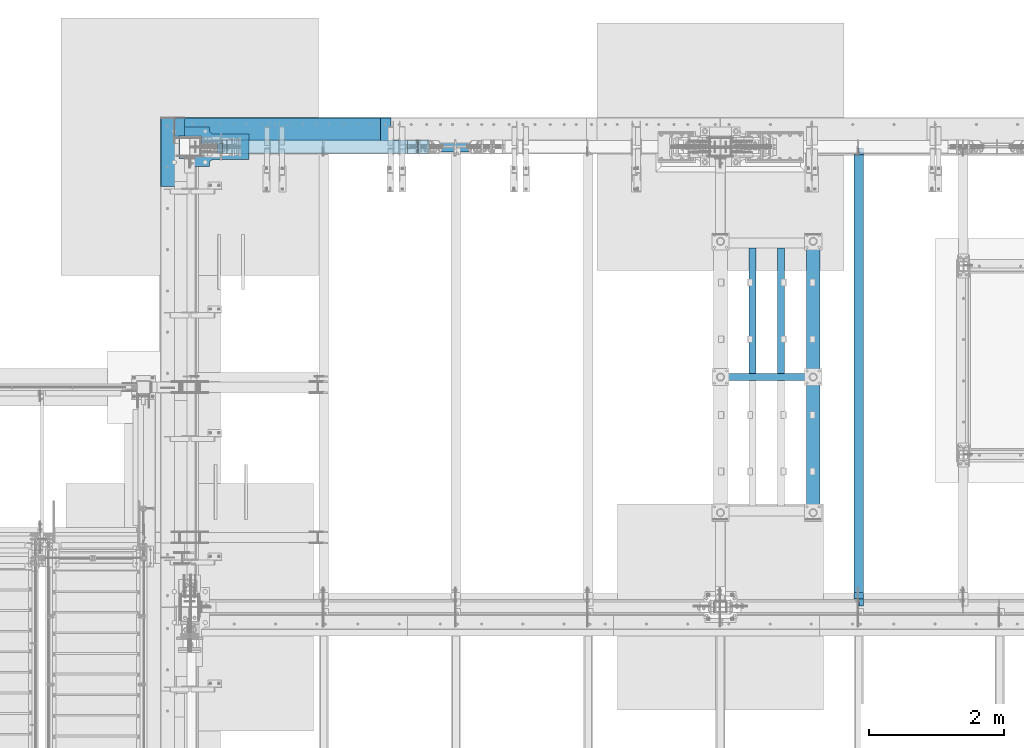
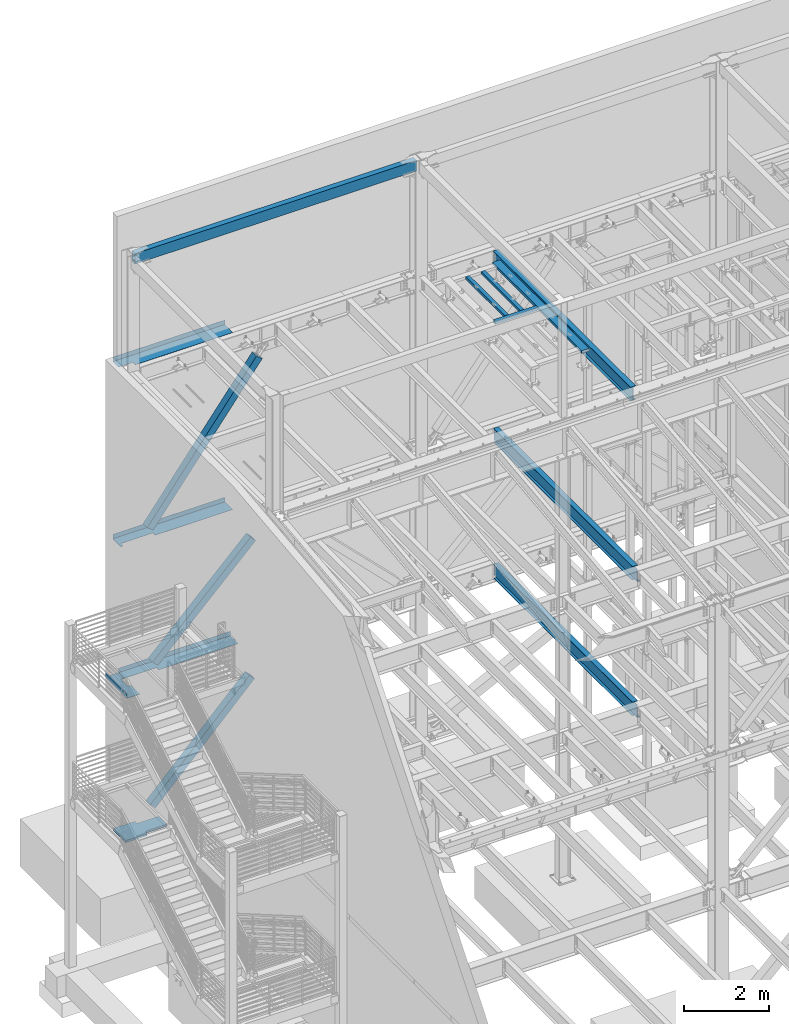
# One storey, part 768 of 1179: 13 beams, 3 members, 13 elements without a shape of their own.
"""IFC2X3 building model written with IfcOpenShell, lengths in millimetres."""

from ifc_helpers import new_model, si_unit, frame, origin_with_axes, place, context, subcontext, project, spatial, faceted_brep, material, type_object, element, aggregate, save


model = new_model("IFC2X3")

# Units and contexts
model_context = context("Model", 3, precision=1e-05, world=origin_with_axes())
body_context = subcontext(model_context, "Body", "Model", "MODEL_VIEW")
ifc_project = project(units=[si_unit("LENGTHUNIT", "METRE", prefix="MILLI"), si_unit("AREAUNIT", "SQUARE_METRE"), si_unit("VOLUMEUNIT", "CUBIC_METRE"), si_unit("MASSUNIT", "GRAM", prefix="KILO"), si_unit("TIMEUNIT", "SECOND"), si_unit("PLANEANGLEUNIT", "RADIAN"), si_unit("SOLIDANGLEUNIT", "STERADIAN"), si_unit("THERMODYNAMICTEMPERATUREUNIT", "DEGREE_CELSIUS"), si_unit("LUMINOUSINTENSITYUNIT", "LUMEN")], contexts=[model_context])

# Site, building, storey
site_placement = place(None, origin_with_axes())
site = spatial("IfcSite", under=ifc_project, at=site_placement, CompositionType="ELEMENT")
building_placement = place(site_placement, origin_with_axes())
building = spatial("IfcBuilding", under=site, at=building_placement, Name="Undefined", CompositionType="ELEMENT")
storey_placement = place(building_placement, origin_with_axes())
storey = spatial("IfcBuildingStorey", under=building, at=storey_placement, Name="Undefined", CompositionType="ELEMENT", Elevation=0.0)

# Assembly, beam
assembly_1_placement = place(storey_placement, origin_with_axes())
assembly_1 = element("IfcElementAssembly", 1, at=assembly_1_placement, inside=storey, Name="BEAM", AssemblyPlace="NOTDEFINED", PredefinedType="RIGID_FRAME")
ifc_material_1 = material(Name="STEEL/A992")
beam_type_1 = type_object("IfcBeamType", Name="W16X31", PredefinedType="NOTDEFINED")
beam_1_placement = place(assembly_1_placement, frame((10325.1, 34391.6, 12917.4875), z_axis=(0.0, 0.0, 1.0), x_axis=(0.0, 1.0, 0.0)))
beam_1 = element("IfcBeam", 2, at=beam_1_placement, type_object=beam_type_1, material=ifc_material_1, Name="BEAM", ObjectType="W16X31", context=body_context, shape_type="Brep", body=[
    faceted_brep([(212.724999999999, 69.8499999999985, -190.5), (212.724999999999, 3.17499999999927, -190.5), (6661.94375000001, 3.17499999999927, -190.5), (6661.94375000001, 69.8499999999985, -190.5), (212.724999999999, -3.17499999999927, -190.5), (212.724999999999, -69.8499999999985, -190.5), (6788.94375000001, -69.8499999999985, -190.5), (6788.94375000001, -3.17499999999927, -190.5), (212.724999999999, -69.8499999999985, -201.612499999999), (6788.94375000001, -69.8499999999985, -201.612499999999), (6788.94375000001, 3.17549991607666, -201.612499999999), (6788.94375000001, 3.17499999999927, -190.5), (6788.94375000001, 3.17499999999927, 163.512499999999), (6788.94375000001, -3.17499999999927, 163.512499999999), (6661.94375000001, 3.17549991607666, -201.612499999999), (212.724999999999, 69.8499999999985, -201.612499999999), (6661.94375000001, 69.8499999999985, -201.612499999999), (212.724999999999, -3.17499999999927, 190.5), (212.724999999999, -69.8499999999985, 190.5), (212.724999999999, -69.8499999999985, 201.612499999999), (212.724999999999, 69.8499999999985, 201.612499999999), (212.724999999999, 69.8499999999985, 190.5), (212.724999999999, 3.17499999999927, 190.5), (212.724999999999, 3.17499999999927, 162.664998864024), (212.724999999999, 3.17499999999927, -142.027500567505), (6696.86875000001, 69.8499999999985, 190.5), (6696.86875000001, 3.17499999999927, 190.5), (6696.86875000001, 3.17499999999927, 176.212499809264), (6697.8354799226, 3.17499999999927, 171.352420291218), (6700.58849382307, 3.17499999999927, 167.232243823064), (6704.70867029123, 3.17499999999927, 164.479229922586), (6709.56874980927, 3.17499999999927, 163.512499999999), (6697.8354799226, -3.17499999999927, 171.352420291218), (6696.86875000001, -3.17499999999927, 176.212499809264), (6700.58849382307, -3.17499999999927, 167.232243823064), (6704.70867029123, -3.17499999999927, 164.479229922586), (6709.56874980927, -3.17499999999927, 163.512499999999), (6696.86875000001, -3.17499999999927, 190.5), (6696.86875000001, -69.8499999999985, 190.5), (6696.86875000001, -69.8499999999985, 201.612499999999), (6696.86875000001, 69.8499999999985, 201.612499999999)], [[[0, 1, 2, 3]], [[4, 5, 6, 7]], [[5, 8, 9, 6]], [[7, 6, 9, 10, 11, 12, 13]], [[11, 10, 14, 2]], [[9, 8, 15, 16, 14, 10]], [[2, 14, 16, 3]], [[15, 0, 3, 16]], [[8, 5, 4, 17, 18, 19, 20, 21, 22, 23, 24, 1, 0, 15]], [[22, 21, 25, 26]], [[11, 2, 1, 24, 23, 22, 26, 27, 28, 29, 30, 31, 12]], [[32, 28, 27, 33]], [[34, 29, 28, 32]], [[35, 30, 29, 34]], [[36, 31, 30, 35]], [[13, 12, 31, 36]], [[35, 34, 32, 33, 37, 17, 4, 7, 13, 36]], [[18, 17, 37, 38]], [[19, 18, 38, 39]], [[20, 19, 39, 40]], [[21, 20, 40, 25]], [[39, 38, 37, 33, 27, 26, 25, 40]]]),
])
aggregate(assembly_1, [beam_1])

assembly_2_placement = place(storey_placement, origin_with_axes())
assembly_2 = element("IfcElementAssembly", 3, at=assembly_2_placement, inside=storey, Name="BEAM", AssemblyPlace="NOTDEFINED", PredefinedType="RIGID_FRAME")
beam_2_placement = place(assembly_2_placement, frame((10325.1, 34391.6, 7812.0875), z_axis=(0.0, 0.0, 1.0), x_axis=(0.0, 1.0, 0.0)))
beam_2 = element("IfcBeam", 4, at=beam_2_placement, type_object=beam_type_1, material=ifc_material_1, Name="BEAM", ObjectType="W16X31", context=body_context, shape_type="Brep", body=[
    faceted_brep([(104.775000190733, -3.17499999999927, 166.6875), (104.775000190733, 3.17497120592088, 166.6875), (17.4624999999942, 3.17499999999927, 166.6875), (17.4624999999942, -3.17499999999927, 166.6875), (109.63507970878, -3.17499999999927, 167.654229922588), (109.63507970878, 3.17497058299341, 167.654229922588), (113.755256176933, -3.17499999999927, 170.407243823066), (113.755256176933, 3.17496880904946, 170.407243823066), (116.508270077407, -3.17499999999927, 174.52742029122), (116.508270077407, 3.17496615415439, 174.52742029122), (117.474999999999, -3.17499999999927, 179.387499809265), (117.474999999999, 3.17496302249128, 179.387499809265), (117.474999999999, -69.8499999999985, 201.6125), (117.474999999999, 69.8499999999985, 201.6125), (117.474999999999, 69.8499999999985, 190.5), (117.474999999999, 3.17499999999927, 190.5), (117.474999999999, -3.17499999999927, 190.5), (117.474999999999, -69.8499999999985, 190.5), (6660.35625, 3.17499999999927, -190.5), (6660.35625, 69.8500000000004, -190.5), (144.462499999994, 69.8499999999985, -190.5), (144.462499999994, 3.17549991607666, -190.5), (17.4624999999942, -3.17499999999927, -190.5), (17.4624999999942, -69.8499999999985, -190.5), (6787.35625, -69.8500000000004, -190.5), (6787.35625, -3.17499999999927, -190.5), (17.4624999999942, -69.8499999999985, -201.6125), (6787.35625, -69.8500000000004, -201.6125), (6660.35625, 69.8500000000004, -201.6125), (6660.35625, 3.17549991607484, -201.6125), (6787.35625, 3.17549991607484, -201.6125), (17.4624999999942, 3.17549991607666, -201.6125), (144.462499999994, 3.17549991607666, -201.6125), (144.462499999994, 69.8499999999985, -201.6125), (17.4624999999942, 3.17499999999927, -190.5), (6787.35625, 3.17499999999927, -190.5), (6787.35625, 3.17499999999927, 157.1625), (6787.35625, -3.17499999999927, 157.1625), (6700.04374980927, 3.17499999999927, 157.1625), (6700.04374980927, -3.17499999999927, 157.1625), (6695.18367029123, 3.17499999999927, 158.129229922588), (6695.18367029123, -3.17499999999927, 158.129229922588), (6691.06349382307, 3.17499999999927, 160.882243823066), (6691.06349382307, -3.17499999999927, 160.882243823066), (6688.31047992259, 3.17499999999927, 165.00242029122), (6688.31047992259, -3.17499999999927, 165.00242029122), (6687.34375000001, 3.17499999999927, 169.862499809266), (6687.34375000001, -3.17499999999927, 169.862499809266), (6687.34375000001, -69.8500000000004, 201.6125), (6687.34375000001, -69.8500000000004, 190.5), (6687.34375000001, -3.17499999999927, 190.5), (6687.34375000001, 3.17499999999927, 190.5), (6687.34375000001, 69.8500000000004, 190.5), (6687.34375000001, 69.8500000000004, 201.6125)], [[[0, 1, 2, 3]], [[4, 5, 1, 0]], [[6, 7, 5, 4]], [[8, 9, 7, 6]], [[10, 11, 9, 8]], [[12, 13, 14, 15, 11, 10, 16, 17]], [[18, 19, 20, 21]], [[22, 23, 24, 25]], [[23, 26, 27, 24]], [[28, 29, 30, 27, 26, 31, 32, 33]], [[21, 32, 31, 34]], [[20, 33, 32, 21]], [[19, 28, 33, 20]], [[18, 29, 28, 19]], [[35, 30, 29, 18]], [[25, 24, 27, 30, 35, 36, 37]], [[37, 36, 38, 39]], [[39, 38, 40, 41]], [[41, 40, 42, 43]], [[43, 42, 44, 45]], [[45, 44, 46, 47]], [[48, 49, 50, 47, 46, 51, 52, 53]], [[49, 48, 12, 17]], [[50, 49, 17, 16]], [[8, 6, 4, 0, 3, 22, 25, 37, 39, 41, 43, 45, 47, 50, 16, 10]], [[34, 31, 26, 23, 22, 3, 2]], [[51, 46, 44, 42, 40, 38, 36, 35, 18, 21, 34, 2, 1, 5, 7, 9, 11, 15]], [[52, 51, 15, 14]], [[53, 52, 14, 13]], [[48, 53, 13, 12]]]),
])
aggregate(assembly_2, [beam_2])

assembly_3_placement = place(storey_placement, origin_with_axes())
assembly_3 = element("IfcElementAssembly", 5, at=assembly_3_placement, inside=storey, Name="BEAM", AssemblyPlace="NOTDEFINED", PredefinedType="RIGID_FRAME")
beam_3_placement = place(assembly_3_placement, frame((10325.1001686096, 34391.6, 3900.4875), z_axis=(0.0, 0.0, 1.0), x_axis=(0.0, 1.0, 0.0)))
beam_3 = element("IfcBeam", 6, at=beam_3_placement, type_object=beam_type_1, material=ifc_material_1, Name="BEAM", ObjectType="W16X31", context=body_context, shape_type="Brep", body=[
    faceted_brep([(113.506251936145, -3.17499999997744, 169.8625), (113.506251936145, 3.17496422017757, 169.8625), (18.2562514952835, 3.17499999999927, 169.8625), (18.2562514952835, -3.17499999999927, 169.8625), (118.366331454192, -3.17499999997926, 170.829229922588), (118.366331454192, 3.17496349569046, 170.829229922588), (122.486507922345, -3.17499999997744, 173.582243823066), (122.486507922345, 3.17496143253265, 173.582243823066), (125.239521822827, -3.17499999997563, 177.70242029122), (125.239521822819, 3.17495834479632, 177.70242029122), (126.206251745411, -3.17499999997744, 182.562499809265), (126.206251745411, 3.1749547025629, 182.562499809265), (126.206251745432, -69.8499999999767, 201.6125), (126.206251745396, 69.850000000024, 201.6125), (126.206251745396, 69.850000000024, 190.5), (126.206251745418, 3.17500000002292, 190.5), (126.206251745411, -3.17499999997744, 190.5), (126.206251745432, -69.8499999999767, 190.5), (6660.35625, 3.17499999999927, -190.5), (6660.35625, 69.8500000000004, -190.5), (145.256250000001, 69.8499999999985, -190.5), (145.256250079394, 3.17558137532069, -190.5), (18.2562500000006, -3.17500000000291, -190.5), (18.2562500000006, -69.8499999999985, -190.5), (6787.35625, -69.8500000000004, -190.5), (6787.35625, -3.17499999999927, -190.5), (18.2562500000006, -69.8499999999985, -201.612499999999), (6787.35625, -69.8500000000004, -201.6125), (6660.35625, 69.8500000000004, -201.6125), (6660.35625, 3.1754070527486, -201.6125), (6787.35625, 3.1754070527486, -201.6125), (18.2562500793938, 3.17558455032122, -201.6125), (145.256250079394, 3.17558137532069, -201.6125), (145.256250000001, 69.8499999999985, -201.612499999999), (18.2562500000006, 3.17500000000291, -190.5), (6787.35625, 3.17499999999927, -190.5), (6787.35625007939, 3.17500000129257, 163.512499999999), (6787.35624992065, -3.17499999870779, 163.512499999999), (6700.04375155555, 3.1750000012762, 163.512499999999), (6700.04375155555, -3.17499999872416, 163.512499999999), (6695.18367203751, 3.1750000012762, 164.479229922587), (6695.18367203751, -3.17499999872416, 164.479229922587), (6691.06349556935, 3.17500000127438, 167.232243823065), (6691.06349556935, -3.17499999872598, 167.232243823065), (6688.31048166887, 3.17500000127438, 171.352420291219), (6688.31048166887, -3.17499999872598, 171.352420291219), (6687.34375174628, 3.17500000127438, 176.212499809265), (6687.34375174629, -3.17499999872598, 176.212499809265), (6687.34375000001, -69.8500000000004, 201.6125), (6687.34375000001, -69.8500000000004, 190.5), (6687.34375000001, -3.17499999999927, 190.5), (6687.34375000001, 3.17499999999927, 190.5), (6687.34375000001, 69.8500000000004, 190.5), (6687.34375000001, 69.8500000000004, 201.6125)], [[[0, 1, 2, 3]], [[4, 5, 1, 0]], [[6, 7, 5, 4]], [[8, 9, 7, 6]], [[10, 11, 9, 8]], [[12, 13, 14, 15, 11, 10, 16, 17]], [[18, 19, 20, 21]], [[22, 23, 24, 25]], [[23, 26, 27, 24]], [[28, 29, 30, 27, 26, 31, 32, 33]], [[21, 32, 31, 34]], [[20, 33, 32, 21]], [[19, 28, 33, 20]], [[18, 29, 28, 19]], [[35, 30, 29, 18]], [[25, 24, 27, 30, 35, 36, 37]], [[37, 36, 38, 39]], [[39, 38, 40, 41]], [[41, 40, 42, 43]], [[43, 42, 44, 45]], [[45, 44, 46, 47]], [[48, 49, 50, 47, 46, 51, 52, 53]], [[49, 48, 12, 17]], [[50, 49, 17, 16]], [[8, 6, 4, 0, 3, 22, 25, 37, 39, 41, 43, 45, 47, 50, 16, 10]], [[34, 31, 26, 23, 22, 3, 2]], [[51, 46, 44, 42, 40, 38, 36, 35, 18, 21, 34, 2, 1, 5, 7, 9, 11, 15]], [[52, 51, 15, 14]], [[53, 52, 14, 13]], [[48, 53, 13, 12]]]),
])
aggregate(assembly_3, [beam_3])

assembly_4_placement = place(storey_placement, origin_with_axes())
assembly_4 = element("IfcElementAssembly", 7, at=assembly_4_placement, inside=storey, Name="BEAM", AssemblyPlace="NOTDEFINED", PredefinedType="RIGID_FRAME")
ifc_material_2 = material(Name="STEEL/A36")
beam_type_2 = type_object("IfcBeamType", PredefinedType="NOTDEFINED")
beam_4_placement = place(assembly_4_placement, frame((1727.1995, 41244.838, 13122.275), z_axis=(-1.0, 0.0, 0.0), x_axis=(0.0, 1.0, 0.0)))
beam_4 = element("IfcBeam", 8, at=beam_4_placement, type_object=beam_type_2, material=ifc_material_2, Name="BENT_PLATE", context=body_context, shape_type="Brep", body=[
    faceted_brep([(117.473999887363, -3.17499999999927, 1128.71250000558), (117.473999887363, 3.17499999999927, 1128.71250000558), (0.0, 3.17499999999927, 1128.71200003614), (0.0, -3.17499999999927, 1128.71200003614), (117.474497999712, -3.17499999999927, 1524.0), (117.474497999712, 3.17499999999927, 1524.0), (379.411999999997, -3.17499999999927, -1524.0), (0.0, -3.17499999999927, -1524.0), (0.0, 3.17499999999927, -1524.0), (385.762000000002, 3.17499999999927, -1524.0), (385.762000000002, -130.175000000001, -1524.0), (379.411999999997, -130.175000000001, -1524.0), (385.762000000002, 3.17499999999927, 1524.0), (385.762000000002, -130.175000000001, 1524.0), (379.411999999997, -130.175000000001, 1524.0), (379.411999999997, -3.17499999999927, 1524.0)], [[[0, 1, 2, 3]], [[4, 5, 1, 0]], [[6, 7, 8, 9, 10, 11]], [[9, 12, 13, 10]], [[14, 11, 10, 13]], [[15, 6, 11, 14]], [[3, 7, 6, 15, 4, 0]], [[8, 7, 3, 2]], [[12, 9, 8, 2, 1, 5]], [[15, 14, 13, 12, 5, 4]]]),
])
aggregate(assembly_4, [beam_4])

assembly_5_placement = place(storey_placement, origin_with_axes())
assembly_5 = element("IfcElementAssembly", 9, at=assembly_5_placement, inside=storey, Name="BEAM", AssemblyPlace="NOTDEFINED", PredefinedType="RIGID_FRAME")
beam_type_3 = type_object("IfcBeamType", PredefinedType="NOTDEFINED")
beam_5_placement = place(assembly_5_placement, frame((1882.77498779297, 41627.425, 4235.45000610352), z_axis=(1.0, 0.0, 0.0), x_axis=(0.0, 0.0, -1.0)))
beam_5 = element("IfcBeam", 10, at=beam_5_placement, type_object=beam_type_3, material=ifc_material_2, Name="BENT_PLATE", context=body_context, shape_type="Brep", body=[
    faceted_brep([(133.350006103513, -265.112499990639, -639.95682176141), (127.000006103513, -265.112499990639, -639.95682176141), (127.000006103513, -265.112500000461, -1524.0), (133.350006103513, -265.112500000461, -1524.0), (133.350006103513, -373.062499990643, -639.956821761311), (127.000006103513, -373.062500000007, -639.956821761311), (0.0, 3.17499999999927, -1524.0), (6.00266503170133e-10, 3.17500000077416, 1524.00000000052), (133.350006103513, 3.17500000000291, 1524.0), (133.350006103513, 3.17500000000291, -1524.0), (0.0, -3.17499999999927, -1524.0), (6.00266503170133e-10, -3.17499999922438, 1524.00000000052), (127.000006103513, -3.17500000000291, -1524.0), (127.000006103513, -3.17500000000291, 1524.0), (127.000006103513, -373.062500000007, 1524.0), (133.350006103513, -373.062500000007, 1524.0)], [[[0, 1, 2, 3]], [[4, 5, 1, 0]], [[6, 7, 8, 9]], [[10, 11, 7, 6]], [[11, 10, 12, 13]], [[8, 7, 11, 13, 14, 15]], [[3, 9, 8, 15, 4, 0]], [[12, 10, 6, 9, 3, 2]], [[14, 13, 12, 2, 1, 5]], [[15, 14, 5, 4]]]),
])
aggregate(assembly_5, [beam_5])

assembly_6_placement = place(storey_placement, origin_with_axes())
assembly_6 = element("IfcElementAssembly", 11, at=assembly_6_placement, inside=storey, Name="BEAM", AssemblyPlace="NOTDEFINED", PredefinedType="RIGID_FRAME")
beam_6_placement = place(assembly_6_placement, frame((1727.20002306546, 41627.425, 8147.05000610352), z_axis=(1.0, 0.0, 0.0), x_axis=(0.0, 0.0, -1.0)))
beam_6 = element("IfcBeam", 12, at=beam_6_placement, type_object=beam_type_3, material=ifc_material_2, Name="BENT_PLATE", context=body_context, shape_type="Brep", body=[
    faceted_brep([(133.350006103513, -373.062500000007, -1455.73752306532), (133.350006103513, -265.11250000001, -1455.73752306556), (127.000006103513, -265.11250000001, -1455.73752306556), (127.000006103513, -373.062500000007, -1455.73752306532), (133.350006103513, -265.112499990159, -581.215178598826), (127.000006103513, -265.112499990159, -581.215178598826), (133.350006103513, -373.062499990163, -581.215178598727), (127.000006103513, -373.062500000007, -581.215178598727), (0.0, -3.17499999999927, -1524.0), (6.00266503170133e-10, -3.17499999922438, 1524.00000000052), (6.00266503170133e-10, 3.17500000077416, 1524.00000000052), (0.0, 3.17499999999927, -1524.0), (133.350006103513, 3.17500000000291, 1524.0), (133.350006103513, 3.17500000000291, -1524.0), (127.000006103513, -3.17500000000291, -1524.0), (133.350006103513, -373.062500000007, -1524.0), (127.000006103513, -373.062500000007, -1524.0), (127.000006103513, -3.17500000000291, 1524.0), (127.000006103513, -373.062500000007, 1524.0), (133.350006103513, -373.062500000007, 1524.0)], [[[0, 1, 2, 3]], [[4, 5, 2, 1]], [[6, 7, 5, 4]], [[8, 9, 10, 11]], [[11, 10, 12, 13]], [[14, 8, 11, 13, 15, 16]], [[9, 8, 14, 17]], [[12, 10, 9, 17, 18, 19]], [[1, 0, 15, 13, 12, 19, 6, 4]], [[16, 15, 0, 3]], [[18, 17, 14, 16, 3, 2, 5, 7]], [[19, 18, 7, 6]]]),
])
aggregate(assembly_6, [beam_6])

# Assembly, member
assembly_7_placement = place(storey_placement, origin_with_axes())
assembly_7 = element("IfcElementAssembly", 13, at=assembly_7_placement, inside=storey, Name="None", AssemblyPlace="NOTDEFINED", PredefinedType="RIGID_FRAME")
member_type = type_object("IfcMemberType", Name="HSS8X8X3/16", PredefinedType="NOTDEFINED")
member_1_placement = place(assembly_7_placement, frame((916.367297799999, 41198.8, 8374.56702098381), z_axis=(0.0, -1.0, 0.0), x_axis=(0.606338778903741, 0.0, 0.795206441873757)))
member_1 = element("IfcMember", 14, at=member_1_placement, type_object=member_type, material=ifc_material_1, Name="None", ObjectType="HSS8X8X3/16", context=body_context, shape_type="Brep", body=[
    faceted_brep([(-3.63797880709171e-12, 96.8374999999978, -96.8375000000015), (-3.63797880709171e-12, -96.8374999999978, -96.8375000000015), (4906.40493070656, -96.8375000009946, -96.8375000000015), (4906.4049307065, 96.8374999990483, -96.8375000000015), (-3.63797880709171e-12, -96.8374999999978, 96.8375000000015), (4906.40493070656, -96.8375000009946, 96.8375000000015), (-3.63797880709171e-12, 96.8374999999978, 96.8375000000015), (4906.4049307065, 96.8374999990483, 96.8375000000015), (-3.63797880709171e-12, 101.599999999999, -101.599999999999), (-3.63797880709171e-12, 101.599999999999, 101.599999999999), (4906.40493070649, 101.599999999049, 101.599999999999), (4906.40493070649, 101.599999999049, -101.599999999999), (0.0, -101.599999999999, 101.599999999999), (4906.40493070656, -101.600000000995, 101.599999999999), (0.0, -101.599999999999, -101.599999999999), (4906.40493070656, -101.600000000995, -101.599999999999)], [[[0, 1, 2, 3]], [[1, 4, 5, 2]], [[4, 6, 7, 5]], [[6, 0, 3, 7]], [[8, 9, 10, 11]], [[9, 12, 13, 10]], [[12, 14, 15, 13]], [[14, 8, 11, 15]], [[13, 15, 11, 10], [5, 7, 3, 2]], [[14, 12, 9, 8], [6, 4, 1, 0]]]),
])
aggregate(assembly_7, [member_1])

assembly_8_placement = place(storey_placement, origin_with_axes())
assembly_8 = element("IfcElementAssembly", 15, at=assembly_8_placement, inside=storey, Name="None", AssemblyPlace="NOTDEFINED", PredefinedType="RIGID_FRAME")
member_2_placement = place(assembly_8_placement, frame((1051.06439794265, 41198.8, 4444.72280631723), z_axis=(0.0, -1.0, 0.0), x_axis=(0.70825189096884, 0.0, 0.705959813968941)))
member_2 = element("IfcMember", 16, at=member_2_placement, type_object=member_type, material=ifc_material_1, Name="None", ObjectType="HSS8X8X3/16", context=body_context, shape_type="Brep", body=[
    faceted_brep([(-3.63797880709171e-12, 96.8374999999978, -96.8375000000015), (-3.63797880709171e-12, -96.8374999999978, -96.8375000000015), (3770.52536925462, -96.837500002066, -96.8375000000015), (3770.52536925472, 96.8374999979314, -96.8375000000015), (-3.63797880709171e-12, -96.8374999999978, 96.8375000000015), (3770.52536925462, -96.837500002066, 96.8375000000015), (-3.63797880709171e-12, 96.8374999999978, 96.8375000000015), (3770.52536925472, 96.8374999979314, 96.8375000000015), (-3.63797880709171e-12, 101.599999999999, -101.599999999999), (-3.63797880709171e-12, 101.599999999999, 101.599999999999), (3770.52536925473, 101.599999997932, 101.599999999999), (3770.52536925473, 101.599999997932, -101.599999999999), (0.0, -101.599999999999, 101.599999999999), (3770.52536925462, -101.600000002065, 101.599999999999), (0.0, -101.599999999999, -101.599999999999), (3770.52536925462, -101.600000002065, -101.599999999999)], [[[0, 1, 2, 3]], [[1, 4, 5, 2]], [[4, 6, 7, 5]], [[6, 0, 3, 7]], [[8, 9, 10, 11]], [[9, 12, 13, 10]], [[12, 14, 15, 13]], [[14, 8, 11, 15]], [[13, 15, 11, 10], [5, 7, 3, 2]], [[14, 12, 9, 8], [6, 4, 1, 0]]]),
])
aggregate(assembly_8, [member_2])

assembly_9_placement = place(storey_placement, origin_with_axes())
assembly_9 = element("IfcElementAssembly", 17, at=assembly_9_placement, inside=storey, Name="None", AssemblyPlace="NOTDEFINED", PredefinedType="RIGID_FRAME")
member_3_placement = place(assembly_9_placement, frame((987.844427358751, 41198.8, 357.014707857615), z_axis=(0.0, -1.0, 0.0), x_axis=(0.696462576035121, 0.0, 0.717593116036186)))
member_3 = element("IfcMember", 18, at=member_3_placement, type_object=member_type, material=ifc_material_1, Name="None", ObjectType="HSS8X8X3/16", context=body_context, shape_type="Brep", body=[
    faceted_brep([(-3.63797880709171e-12, 96.8374999999978, -96.8375000000015), (-3.63797880709171e-12, -96.8374999999978, -96.8375000000015), (3876.67499999912, -96.8374999988628, -96.8375000000015), (3876.67499999909, 96.837500001162, -96.8375000000015), (-3.63797880709171e-12, -96.8374999999978, 96.8375000000015), (3876.67499999912, -96.8374999988628, 96.8375000000015), (-3.63797880709171e-12, 96.8374999999978, 96.8375000000015), (3876.67499999909, 96.837500001162, 96.8375000000015), (-3.63797880709171e-12, 101.599999999999, -101.599999999999), (-3.63797880709171e-12, 101.599999999999, 101.599999999999), (3876.67499999909, 101.600000001163, 101.599999999999), (3876.67499999909, 101.600000001163, -101.599999999999), (0.0, -101.599999999999, 101.599999999999), (3876.67499999912, -101.599999998863, 101.599999999999), (0.0, -101.599999999999, -101.599999999999), (3876.67499999912, -101.599999998863, -101.599999999999)], [[[0, 1, 2, 3]], [[1, 4, 5, 2]], [[4, 6, 7, 5]], [[6, 0, 3, 7]], [[8, 9, 10, 11]], [[9, 12, 13, 10]], [[12, 14, 15, 13]], [[14, 8, 11, 15]], [[13, 15, 11, 10], [5, 7, 3, 2]], [[14, 12, 9, 8], [6, 4, 1, 0]]]),
])
aggregate(assembly_9, [member_3])

# Assembly, beam
assembly_10_placement = place(storey_placement, origin_with_axes())
assembly_10 = element("IfcElementAssembly", 19, at=assembly_10_placement, inside=storey, Name="BEAM", AssemblyPlace="NOTDEFINED", PredefinedType="RIGID_FRAME")
beam_type_4 = type_object("IfcBeamType", PredefinedType="NOTDEFINED")
beam_7_placement = place(assembly_10_placement, frame((352.424987792968, 41122.6, 4105.275), z_axis=(0.0, -1.0, 0.0), x_axis=(-1.0, 0.0, 0.0)))
beam_7 = element("IfcBeam", 20, at=beam_7_placement, type_object=beam_type_4, material=ifc_material_2, Name="BENT_PLATE", context=body_context, shape_type="Brep", body=[
    faceted_brep([(80.9624862670794, -3.17500000000018, -239.712500000001), (80.9624862670794, 3.17500000000018, -239.712500000001), (0.0, 3.17500000000018, -239.712499999994), (0.0, -3.17500000000018, -239.712499999994), (80.9624862670869, -3.17500000000018, 93.6624999999985), (80.9624862670869, 3.17500000000018, 93.6624999999985), (0.0, -3.17500000000018, 93.6624999999985), (0.0, 3.17500000000018, 93.6624999999985), (346.074987792969, -3.17500000000109, 508.0), (346.074987792969, -3.17500000000109, -508.0), (346.074987792969, -130.175006103515, -508.0), (346.074987792969, -130.175006103515, 508.0), (352.424987792969, 3.17499999999927, 508.0), (0.0, 3.17500000000018, 508.0), (0.0, -3.17500000000018, 508.0), (352.424987792969, -130.175006103515, 508.0), (352.424987792969, 3.17499999999927, -508.0), (352.424987792969, -130.175006103515, -508.0), (0.0, -3.17500000000018, -508.0), (0.0, 3.17500000000018, -508.0)], [[[0, 1, 2, 3]], [[4, 5, 1, 0]], [[6, 7, 5, 4]], [[8, 9, 10, 11]], [[12, 13, 14, 8, 11, 15]], [[16, 12, 15, 17]], [[11, 10, 17, 15]], [[9, 18, 19, 16, 17, 10]], [[19, 18, 3, 2]], [[13, 12, 16, 19, 2, 1, 5, 7]], [[14, 13, 7, 6]], [[3, 18, 9, 8, 14, 6, 4, 0]]]),
])
aggregate(assembly_10, [beam_7])

# Assembly, beams
assembly_11_placement = place(storey_placement, origin_with_axes())
assembly_11 = element("IfcElementAssembly", 21, at=assembly_11_placement, inside=storey, Name="FRAME", AssemblyPlace="NOTDEFINED", PredefinedType="RIGID_FRAME")
ifc_material_3 = material()
beam_type_5 = type_object("IfcBeamType", Name="HSS4X3X1/4", PredefinedType="NOTDEFINED")
beam_8_placement = place(assembly_11_placement, frame((9177.86666666667, 37845.3344873485, 13722.35), z_axis=(1.0, 0.0, 0.0), x_axis=(0.0, 1.0, 0.0)))
beam_8 = element("IfcBeam", 22, at=beam_8_placement, type_object=beam_type_5, material=ifc_material_3, Name="BEAM", ObjectType="HSS4X3X1/4", context=body_context, shape_type="Brep", body=[
    faceted_brep([(0.0, 31.75, -44.4499999999971), (0.0, -31.75, -44.4499999999971), (1854.2, -31.75, -44.4500000000007), (1854.2, 31.75, -44.4500000000007), (0.0, -31.75, 44.4499999999971), (1854.2, -31.75, 44.4500000000007), (0.0, 31.75, 44.4499999999971), (1854.2, 31.75, 44.4500000000007), (0.0, 38.0999999999985, -50.8000000000002), (1.45519152283669e-11, 38.1000000000004, 50.8000000000002), (1854.2, 38.1000000000004, 50.7999999999993), (1854.2, 38.1000000000004, -50.7999999999993), (0.0, -38.0999999999985, 50.8000000000002), (1854.2, -38.1000000000004, 50.7999999999993), (0.0, -38.0999999999985, -50.8000000000002), (1854.2, -38.1000000000004, -50.7999999999993)], [[[0, 1, 2, 3]], [[1, 4, 5, 2]], [[4, 6, 7, 5]], [[6, 0, 3, 7]], [[8, 9, 10, 11]], [[9, 12, 13, 10]], [[12, 14, 15, 13]], [[14, 8, 11, 15]], [[13, 15, 11, 10], [5, 7, 3, 2]], [[14, 12, 9, 8], [6, 4, 1, 0]]]),
])
beam_9_placement = place(assembly_11_placement, frame((8754.53333333333, 37845.3344873485, 13722.35), z_axis=(1.0, 0.0, 0.0), x_axis=(0.0, 1.0, 0.0)))
beam_9 = element("IfcBeam", 23, at=beam_9_placement, type_object=beam_type_5, material=ifc_material_3, Name="BEAM", ObjectType="HSS4X3X1/4", context=body_context, shape_type="Brep", body=[
    faceted_brep([(0.0, 31.75, -44.4499999999971), (0.0, -31.75, -44.4499999999971), (1854.2, -31.75, -44.4500000000007), (1854.2, 31.75, -44.4500000000007), (0.0, -31.75, 44.4499999999971), (1854.2, -31.75, 44.4500000000007), (0.0, 31.75, 44.4499999999971), (1854.2, 31.75, 44.4500000000007), (0.0, 38.0999999999985, -50.8000000000002), (1.45519152283669e-11, 38.1000000000004, 50.8000000000002), (1854.2, 38.1000000000004, 50.7999999999993), (1854.2, 38.1000000000004, -50.7999999999993), (0.0, -38.0999999999985, 50.8000000000002), (1854.2, -38.1000000000004, 50.7999999999993), (0.0, -38.0999999999985, -50.8000000000002), (1854.2, -38.1000000000004, -50.7999999999993)], [[[0, 1, 2, 3]], [[1, 4, 5, 2]], [[4, 6, 7, 5]], [[6, 0, 3, 7]], [[8, 9, 10, 11]], [[9, 12, 13, 10]], [[12, 14, 15, 13]], [[14, 8, 11, 15]], [[13, 15, 11, 10], [5, 7, 3, 2]], [[14, 12, 9, 8], [6, 4, 1, 0]]]),
])
beam_10_placement = place(assembly_11_placement, frame((8382.0, 37794.5344873485, 13722.35), z_axis=(0.0, -1.0, 0.0), x_axis=(1.0, 0.0, 0.0)))
beam_10 = element("IfcBeam", 24, at=beam_10_placement, type_object=beam_type_5, material=ifc_material_3, Name="BEAM", ObjectType="HSS4X3X1/4", context=body_context, shape_type="Brep", body=[
    faceted_brep([(0.0, 31.75, -44.4499999999971), (0.0, -31.75, -44.4499999999971), (1168.4, -31.75, -44.4499999999971), (1168.4, 31.75, -44.4499999999971), (0.0, -31.75, 44.4499999999971), (1168.4, -31.75, 44.4499999999971), (0.0, 31.75, 44.4499999999971), (1168.4, 31.75, 44.4499999999971), (0.0, 38.0999999999985, -50.8000000000002), (1.45519152283669e-11, 38.1000000000004, 50.8000000000002), (1168.4, 38.1000000000004, 50.8000000000029), (1168.4, 38.1000000000004, -50.8000000000029), (0.0, -38.0999999999985, 50.8000000000002), (1168.4, -38.1000000000004, 50.8000000000029), (0.0, -38.0999999999985, -50.8000000000002), (1168.4, -38.1000000000004, -50.8000000000029)], [[[0, 1, 2, 3]], [[1, 4, 5, 2]], [[4, 6, 7, 5]], [[6, 0, 3, 7]], [[8, 9, 10, 11]], [[9, 12, 13, 10]], [[12, 14, 15, 13]], [[14, 8, 11, 15]], [[13, 15, 11, 10], [5, 7, 3, 2]], [[14, 12, 9, 8], [6, 4, 1, 0]]]),
])
beam_type_6 = type_object("IfcBeamType", Name="HSS8X3X1/4", PredefinedType="NOTDEFINED")
beam_11_placement = place(assembly_11_placement, frame((9652.0, 35686.3344873485, 13722.35), z_axis=(1.0, 0.0, 0.0), x_axis=(0.0, 1.0, 0.0)))
beam_11 = element("IfcBeam", 25, at=beam_11_placement, type_object=beam_type_6, material=ifc_material_3, Name="BEAM", ObjectType="HSS8X3X1/4", context=body_context, shape_type="Brep", body=[
    faceted_brep([(4.76249999999709, 31.75, -95.25), (4.76249999999709, -31.75, -95.25), (4211.6375, -31.75, -95.25), (4211.6375, 31.75, -95.25), (4.76249999999709, -31.75, 95.25), (4211.6375, -31.75, 95.25), (4.76249999999709, 31.75, 95.25), (4211.6375, 31.75, 95.25), (4.76249999999709, 38.1000000000004, -101.599999999999), (4.76249999999709, 38.1000000000004, 101.599999999999), (4211.6375, 38.1000000000004, 101.6), (4211.6375, 38.1000000000004, -101.6), (4.76249999999709, -38.1000000000004, 101.599999999999), (4211.6375, -38.1000000000004, 101.6), (4.76249999999709, -38.1000000000004, -101.599999999999), (4211.6375, -38.1000000000004, -101.6)], [[[0, 1, 2, 3]], [[1, 4, 5, 2]], [[4, 6, 7, 5]], [[6, 0, 3, 7]], [[8, 9, 10, 11]], [[9, 12, 13, 10]], [[12, 14, 15, 13]], [[14, 8, 11, 15]], [[13, 15, 11, 10], [5, 7, 3, 2]], [[14, 12, 9, 8], [6, 4, 1, 0]]]),
])
aggregate(assembly_11, [beam_8, beam_9, beam_10, beam_11])

# Assembly, beam
assembly_12_placement = place(storey_placement, origin_with_axes())
assembly_12 = element("IfcElementAssembly", 26, at=assembly_12_placement, inside=storey, Name="BEAM", AssemblyPlace="NOTDEFINED", PredefinedType="RIGID_FRAME")
beam_type_7 = type_object("IfcBeamType", Name="HSS12X6X3/8", PredefinedType="NOTDEFINED")
beam_12_placement = place(assembly_12_placement, frame((509.58750000001, 41198.8, 16275.05), z_axis=(0.0, 0.0, 1.0), x_axis=(1.0, 0.0, 0.0)))
beam_12 = element("IfcBeam", 27, at=beam_12_placement, type_object=beam_type_7, material=ifc_material_3, Name="BEAM", ObjectType="HSS12X6X3/8", context=body_context, shape_type="Brep", body=[
    faceted_brep([(9.52500000000146, 66.675, -142.875), (9.52500000000146, -66.675, -142.875), (7683.49999897386, -66.6750000000029, -142.875), (7683.49999897386, 66.6750000000029, -142.875), (9.52500000000146, -66.675, 142.875000000002), (7683.49999897386, -66.6750000000029, 142.875000000002), (9.52500000000146, 66.675, 142.875000000002), (7683.49999897386, 66.6750000000029, 142.875000000002), (9.52500000000146, 76.2, -152.4), (9.52500000000146, 76.2, 152.4), (7683.49999897386, 76.1999999999971, 152.4), (7683.49999897386, 76.1999999999971, -152.4), (9.52500000000146, -76.2, 152.4), (7683.49999897386, -76.1999999999971, 152.4), (9.52500000000146, -76.2, -152.4), (7683.49999897386, -76.1999999999971, -152.4)], [[[0, 1, 2, 3]], [[1, 4, 5, 2]], [[4, 6, 7, 5]], [[6, 0, 3, 7]], [[8, 9, 10, 11]], [[9, 12, 13, 10]], [[12, 14, 15, 13]], [[14, 8, 11, 15]], [[13, 15, 11, 10], [5, 7, 3, 2]], [[14, 12, 9, 8], [6, 4, 1, 0]]]),
])
aggregate(assembly_12, [beam_12])

assembly_13_placement = place(storey_placement, origin_with_axes())
assembly_13 = element("IfcElementAssembly", 28, at=assembly_13_placement, inside=storey, Name="COLUMN", AssemblyPlace="NOTDEFINED", PredefinedType="RIGID_FRAME")
ifc_material_4 = material(Name="STEEL/A572-GR.50")
beam_type_8 = type_object("IfcBeamType", PredefinedType="NOTDEFINED")
beam_13_placement = place(assembly_13_placement, frame((139.700503540043, 41198.8, -247.65), z_axis=(0.0, 1.0, 0.0), x_axis=(1.0, 0.0, 0.0)))
beam_13 = element("IfcBeam", 29, at=beam_13_placement, type_object=beam_type_8, material=ifc_material_4, context=body_context, shape_type="Brep", body=[
    faceted_brep([(584.199496459958, -31.75, 292.1), (584.199496459958, -31.75, 241.30000076336), (584.199496459958, 31.75, 241.30000076336), (584.199496459958, 31.75, 292.1), (588.066416150308, -31.75, 221.859682691178), (588.066416150308, 31.75, 221.859682691178), (599.078471752222, -31.75, 205.378976818563), (599.078471752222, 31.75, 205.378976818563), (615.559177624837, -31.75, 194.366921216651), (615.559177624837, 31.75, 194.366921216651), (634.999495697019, -31.75, 190.500001526299), (634.999495697019, 31.75, 190.500001526299), (1168.39847106933, -31.75, 190.500001526299), (1168.39848937988, 31.75, 190.500001526299), (0.0, -31.75, -292.1), (0.0, -31.75, 292.1), (0.0, 31.75, 292.1), (0.0, 31.75, -292.1), (584.199496459958, 31.75, -292.1), (584.199496459958, -31.75, -292.1), (584.199496459958, 31.75, -241.30000076336), (584.199496459958, -31.75, -241.30000076336), (588.066416150308, 31.75, -221.859682691178), (588.066416150308, -31.75, -221.859682691178), (599.078471752222, 31.75, -205.378976818563), (599.078471752222, -31.75, -205.378976818563), (615.559177624837, 31.75, -194.366921216651), (615.559177624837, -31.75, -194.366921216651), (634.999495697019, 31.75, -190.500001526299), (634.999495697019, -31.75, -190.500001526299), (1168.39847106933, -31.75, -190.500001526299), (1168.39848937988, 31.75, -190.500001526299)], [[[0, 1, 2, 3]], [[4, 5, 2, 1]], [[6, 7, 5, 4]], [[8, 9, 7, 6]], [[10, 11, 9, 8]], [[12, 13, 11, 10]], [[14, 15, 16, 17]], [[14, 17, 18, 19]], [[19, 18, 20, 21]], [[21, 20, 22, 23]], [[23, 22, 24, 25]], [[25, 24, 26, 27]], [[27, 26, 28, 29]], [[30, 29, 28, 31]], [[8, 6, 4, 1, 0, 15, 14, 19, 21, 23, 25, 27, 29, 30, 12, 10]], [[16, 15, 0, 3]], [[31, 28, 26, 24, 22, 20, 18, 17, 16, 3, 2, 5, 7, 9, 11, 13]], [[30, 31, 13, 12]]]),
])
aggregate(assembly_13, [beam_13])

save(model, "model.ifc")
